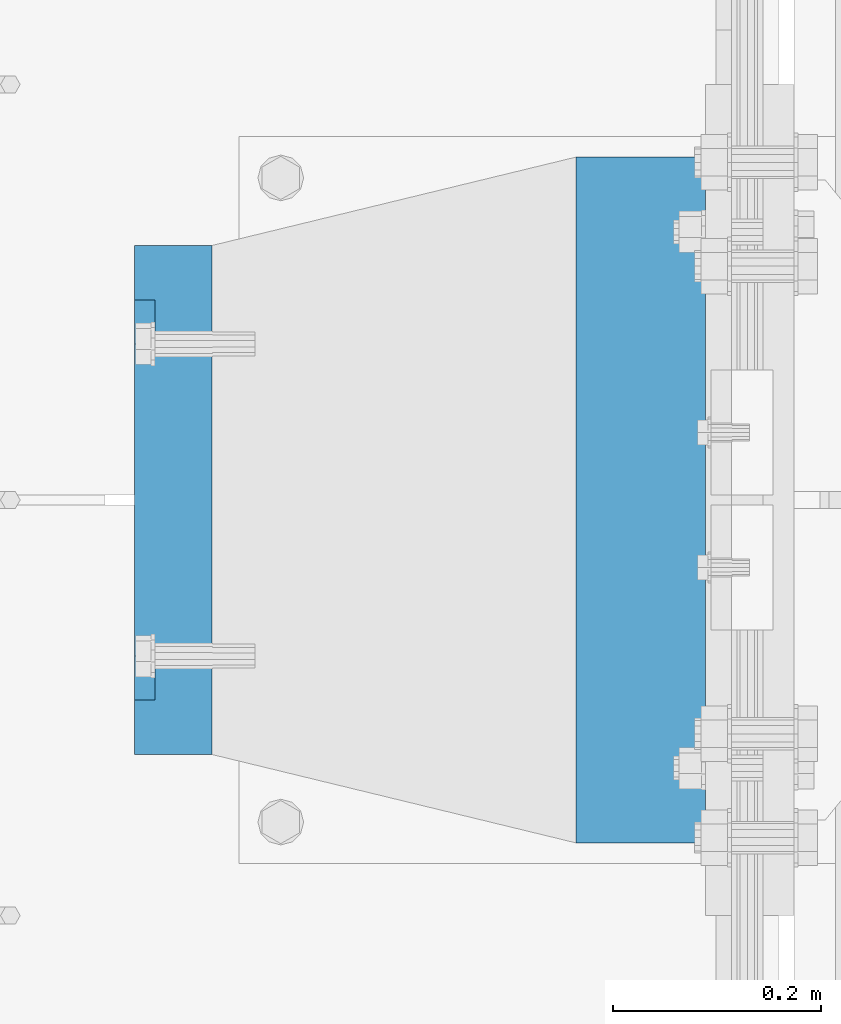
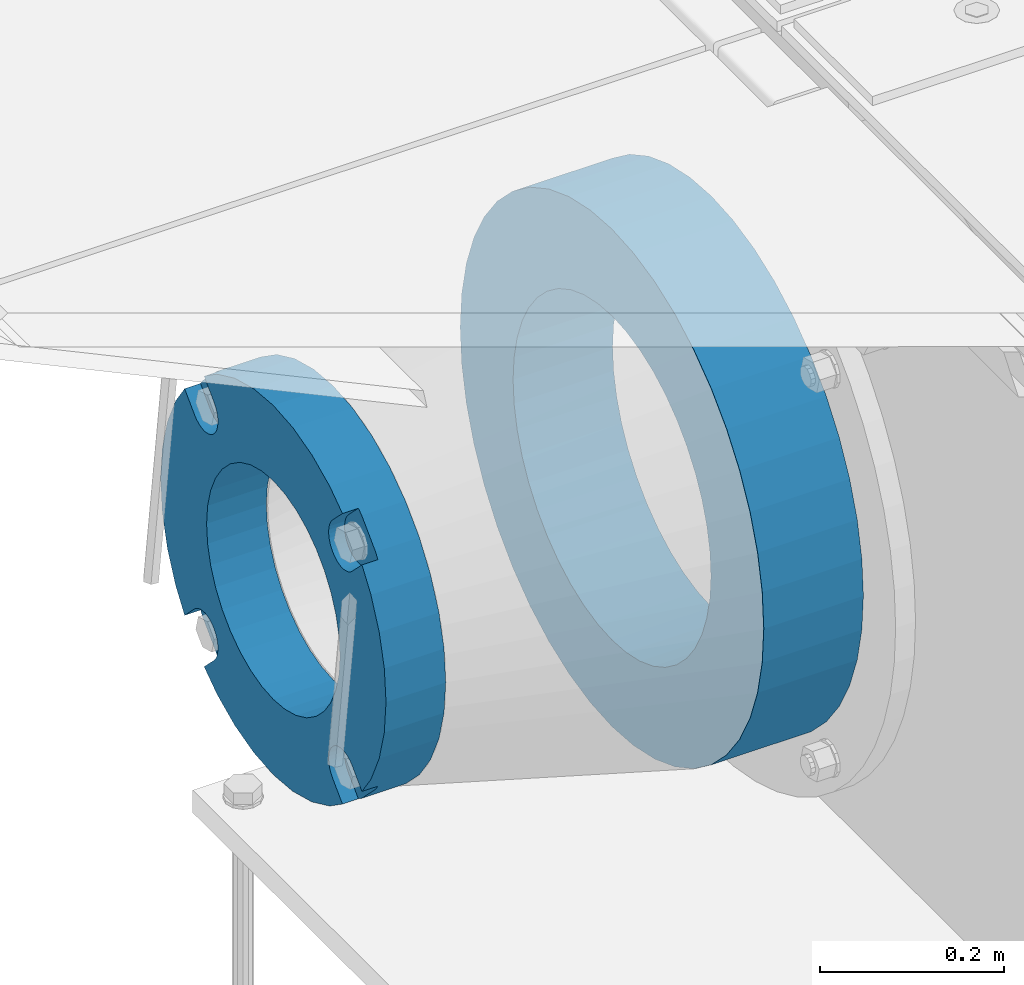
# One storey, part 144 of 257: 2 beams.
"""IFC2X3 building model written with IfcOpenShell, lengths in millimetres."""

from ifc_helpers import new_model, si_unit, frame, origin_with_axes, place, context, subcontext, project, spatial, faceted_brep, material, type_object, element, save


model = new_model("IFC2X3")

# Units and contexts
model_context = context("Model", 3, precision=1e-05, world=origin_with_axes())
body_context = subcontext(model_context, "Body", "Model", "MODEL_VIEW")
ifc_project = project(units=[si_unit("LENGTHUNIT", "METRE", prefix="MILLI"), si_unit("AREAUNIT", "SQUARE_METRE"), si_unit("VOLUMEUNIT", "CUBIC_METRE"), si_unit("MASSUNIT", "GRAM", prefix="KILO"), si_unit("TIMEUNIT", "SECOND"), si_unit("PLANEANGLEUNIT", "RADIAN"), si_unit("SOLIDANGLEUNIT", "STERADIAN"), si_unit("THERMODYNAMICTEMPERATUREUNIT", "DEGREE_CELSIUS"), si_unit("LUMINOUSINTENSITYUNIT", "LUMEN")], contexts=[model_context])

# Site, building, storey
site_placement = place(None, origin_with_axes())
site = spatial("IfcSite", under=ifc_project, at=site_placement, CompositionType="ELEMENT")
building_placement = place(site_placement, origin_with_axes())
building = spatial("IfcBuilding", under=site, at=building_placement, Name="Standard", CompositionType="ELEMENT")
storey_placement = place(building_placement, origin_with_axes())
storey = spatial("IfcBuildingStorey", under=building, at=storey_placement, Name="Undefined", CompositionType="ELEMENT", Elevation=0.0)

# Beams
ifc_material_1 = material(Name="SCN-500-E2")
beam_type_1 = type_object("IfcBeamType", PredefinedType="NOTDEFINED")
beam_1_placement = place(storey_placement, frame((41900.0, 9000.00000146624, -515.0), z_axis=(0.0, 0.0, 1.0), x_axis=(-1.0, 0.0, 0.0)))
element("IfcBeam", 1, at=beam_1_placement, inside=storey, type_object=beam_type_1, material=ifc_material_1, context=body_context, shape_type="Brep", body=[
    faceted_brep([(75.0, 192.717024793295, -150.290616455866), (75.0000000000073, 171.473395903973, -129.046987566545), (55.0, 171.473395903973, -129.046987566545), (55.0, 192.717024793295, -150.290616455866), (75.0000000000073, 167.467485558908, -125.685629673472), (55.0, 167.467485558908, -125.685629673472), (75.0000000000073, 162.938740320598, -123.070957391043), (55.0, 162.938740320598, -123.070957391043), (75.0000000000073, 158.024763821452, -121.28241621347), (55.0, 158.024763821452, -121.28241621347), (75.0000000000073, 152.874864750806, -120.37435005939), (55.0, 152.874864750806, -120.37435005939), (75.0000000000073, 147.645520185947, -120.37435005939), (55.0, 147.645520185947, -120.37435005939), (75.0000000000073, 142.495621115301, -121.28241621347), (55.0, 142.495621115301, -121.28241621347), (75.0000000000073, 137.581644616156, -123.070957391043), (55.0, 137.581644616156, -123.070957391043), (75.0000000000073, 133.052899377846, -125.685629673472), (55.0, 133.052899377846, -125.685629673472), (75.0000000000073, 129.04698903278, -129.046987566545), (55.0, 129.04698903278, -129.046987566545), (75.0000000000073, 125.685631139707, -133.05289791161), (55.0, 125.685631139707, -133.05289791161), (75.0000000000073, 123.070958857277, -137.58164314992), (55.0, 123.070958857277, -137.58164314992), (75.0000000000073, 121.282417679704, -142.495619649066), (55.0, 121.282417679704, -142.495619649066), (75.0, 120.374351525624, -147.645518719712), (55.0, 120.374351525624, -147.645518719712), (75.0, 120.374351525624, -152.874863284572), (55.0, 120.374351525624, -152.874863284572), (75.0000000000073, 121.282417679704, -158.024762355218), (55.0, 121.282417679704, -158.024762355218), (75.0000000000073, 123.070958857277, -162.938738854363), (55.0, 123.070958857277, -162.938738854363), (75.0000000000073, 125.685631139707, -167.467484092674), (55.0, 125.685631139707, -167.467484092674), (75.0000000000073, 129.04698903278, -171.473394437738), (55.0, 129.04698903278, -171.473394437738), (55.0, 150.290618180639, -192.717023585596), (75.0, 150.290618180639, -192.717023585596), (55.0, 157.482964373202, -187.68088856415), (55.0, 187.68088856415, -157.482964373202), (75.0, -192.717023585595, 150.29061818064), (75.0000000000073, -171.4733929715, 129.046987566545), (55.0, -171.4733929715, 129.046987566545), (55.0, -192.717023585596, 150.29061818064), (75.0000000000073, -167.467482626435, 125.685629673472), (55.0, -167.467482626435, 125.685629673472), (75.0000000000073, -162.938737388125, 123.070957391043), (55.0, -162.938737388125, 123.070957391043), (75.0000000000073, -158.024760888979, 121.28241621347), (55.0, -158.024760888979, 121.28241621347), (75.0000000000073, -152.874861818334, 120.37435005939), (55.0, -152.874861818334, 120.37435005939), (75.0000000000073, -147.645517253474, 120.37435005939), (55.0, -147.645517253474, 120.37435005939), (75.0000000000073, -142.495618182828, 121.28241621347), (55.0, -142.495618182828, 121.28241621347), (75.0, -137.581641683683, 123.070957391043), (55.0, -137.581641683683, 123.070957391043), (75.0, -133.052896445373, 125.685629673473), (55.0, -133.052896445373, 125.685629673473), (75.0, -129.046986100308, 129.046987566545), (55.0, -129.046986100308, 129.046987566545), (75.0, -125.685628207234, 133.05289791161), (55.0, -125.685628207234, 133.05289791161), (75.0, -123.070955924804, 137.581643149921), (55.0, -123.070955924804, 137.581643149921), (75.0, -121.282414747231, 142.495619649066), (55.0, -121.282414747231, 142.495619649066), (75.0, -120.374348593151, 147.645518719712), (55.0, -120.374348593151, 147.645518719712), (75.0, -120.374348593151, 152.874863284572), (55.0, -120.374348593151, 152.874863284572), (75.0, -121.282414747231, 158.024762355218), (55.0, -121.282414747231, 158.024762355218), (75.0, -123.070955924804, 162.938738854364), (55.0, -123.070955924804, 162.938738854364), (75.0, -125.685628207234, 167.467484092675), (55.0, -125.685628207234, 167.467484092675), (75.0, -129.046986100308, 171.473394437738), (55.0, -129.046986100308, 171.473394437738), (55.0, -150.290616455865, 192.717024793296), (75.0, -150.290616455865, 192.717024793296), (75.0, 150.290618180638, 192.717023585597), (75.0, 129.04698903278, 171.473394437739), (55.0, 129.04698903278, 171.473394437739), (55.0, 150.290618180638, 192.717023585597), (75.0, 125.685631139708, 167.467484092674), (55.0, 125.685631139708, 167.467484092674), (75.0, 123.070958857278, 162.938738854363), (55.0, 123.070958857278, 162.938738854363), (75.0, 121.282417679706, 158.024762355218), (55.0, 121.282417679706, 158.024762355218), (75.0, 120.374351525625, 152.874863284572), (55.0, 120.374351525625, 152.874863284572), (75.0, 120.374351525625, 147.645518719713), (55.0, 120.374351525625, 147.645518719713), (75.0, 121.282417679706, 142.495619649067), (55.0, 121.282417679706, 142.495619649067), (75.0, 123.070958857278, 137.581643149922), (55.0, 123.070958857278, 137.581643149922), (75.0, 125.685631139708, 133.052897911612), (55.0, 125.685631139708, 133.052897911612), (75.0, 129.04698903278, 129.046987566546), (55.0, 129.04698903278, 129.046987566546), (75.0, 133.052899377845, 125.685629673472), (55.0, 133.052899377845, 125.685629673472), (75.0, 137.581644616156, 123.070957391043), (55.0, 137.581644616156, 123.070957391043), (75.0, 142.495621115301, 121.28241621347), (55.0, 142.495621115301, 121.28241621347), (75.0, 147.645520185948, 120.37435005939), (55.0, 147.645520185948, 120.37435005939), (75.0, 152.874864750807, 120.37435005939), (55.0, 152.874864750807, 120.37435005939), (75.0, 158.024763821453, 121.28241621347), (55.0, 158.024763821453, 121.28241621347), (75.0, 162.938740320599, 123.070957391043), (55.0, 162.938740320599, 123.070957391043), (75.0, 167.46748555891, 125.685629673472), (55.0, 167.46748555891, 125.685629673472), (75.0, 171.473395903973, 129.046987566546), (55.0, 171.473395903973, 129.046987566546), (55.0, 192.717024793294, 150.290616455867), (75.0, 192.717024793294, 150.290616455867), (0.0, 212.176223927188, -122.5), (0.0, 230.224692092548, -83.7949351147888), (75.0, 230.224692092548, -83.7949351147888), (75.0, 212.176223927188, -122.5), (0.0, 241.277899487991, -42.5438035283978), (75.0, 241.277899487991, -42.5438035283978), (0.0, 245.0, 0.0), (75.0, 245.0, 0.0), (0.0, 241.277899487991, 42.543803528398), (75.0, 241.277899487991, 42.543803528398), (0.0, 230.224692092548, 83.7949351147889), (75.0, 230.224692092548, 83.7949351147889), (0.0, 212.176223927187, 122.5), (75.0, 212.176223927187, 122.5), (0.0, 187.68088856415, 157.482964373202), (55.0, 187.68088856415, 157.482964373202), (0.0, 157.482964373202, 187.68088856415), (55.0, 157.482964373202, 187.68088856415), (0.0, 122.5, 212.176223927187), (75.0, 122.5, 212.176223927187), (0.0, 83.7949351147888, 230.224692092548), (75.0, 83.7949351147888, 230.224692092548), (0.0, 42.5438035283979, 241.277899487991), (75.0, 42.5438035283979, 241.277899487991), (0.0, -1.50019233485983e-14, 245.0), (75.0, -1.50019233485983e-14, 245.0), (0.0, -42.543803528398, 241.277899487991), (75.0, -42.543803528398, 241.277899487991), (0.0, -83.7949351147889, 230.224692092548), (75.0, -83.7949351147889, 230.224692092548), (0.0, -122.5, 212.176223927187), (75.0, -122.5, 212.176223927187), (0.0, -157.482964373202, 187.68088856415), (55.0, -157.482964373202, 187.68088856415), (0.0, -187.68088856415, 157.482964373202), (55.0, -187.68088856415, 157.482964373202), (0.0, -212.176223927187, 122.5), (75.0, -212.176223927187, 122.5), (0.0, -230.224692092548, 83.7949351147888), (75.0, -230.224692092548, 83.7949351147888), (0.0, -241.277899487991, 42.5438035283979), (75.0, -241.277899487991, 42.5438035283979), (0.0, -245.0, 0.0), (75.0, -245.0, 0.0), (0.0, -187.68088856415, -157.482964373202), (0.0, -157.482964373202, -187.68088856415), (55.0, -157.482964373202, -187.68088856415), (55.0, -187.68088856415, -157.482964373202), (0.0, 83.794935114789, -230.224692092547), (0.0, 122.5, -212.176223927187), (75.0, 122.5, -212.176223927187), (75.0, 83.794935114789, -230.224692092547), (0.0, 42.5438035283979, -241.277899487991), (75.0, 42.5438035283979, -241.277899487991), (0.0, 4.50057698340366e-14, -245.0), (75.0, 4.50057698340366e-14, -245.0), (0.0, -42.5438035283978, -241.277899487991), (75.0, -42.5438035283978, -241.277899487991), (0.0, -83.7949351147887, -230.224692092548), (75.0, -83.7949351147887, -230.224692092548), (0.0, -122.5, -212.176223927187), (75.0, -122.5, -212.176223927187), (75.0, -150.290616455865, -192.717024793296), (55.0, -150.290616455865, -192.717024793296), (55.0, -129.046986100307, -171.473394437739), (55.0, -125.685628207235, -167.467484092674), (55.0, -123.070955924805, -162.938738854363), (55.0, -121.282414747233, -158.024762355218), (55.0, -120.374348593152, -152.874863284572), (55.0, -120.374348593153, -147.645518719713), (55.0, -121.282414747233, -142.495619649067), (55.0, -123.070955924805, -137.581643149922), (55.0, -125.685628207235, -133.052897911612), (55.0, -129.046986100307, -129.046987566546), (55.0, -133.052896445372, -125.685629673472), (55.0, -137.581641683683, -123.070957391043), (55.0, -142.495618182829, -121.28241621347), (55.0, -147.645517253475, -120.37435005939), (55.0, -152.874861818334, -120.37435005939), (55.0, -158.024760888981, -121.28241621347), (55.0, -162.938737388126, -123.070957391043), (55.0, -167.467482626437, -125.685629673472), (55.0, -171.4733929715, -129.046987566546), (55.0, -192.717023585595, -150.290618180641), (75.0, -129.046986100307, -171.473394437739), (75.0, -125.685628207235, -167.467484092674), (75.0, -123.070955924805, -162.938738854363), (75.0, -121.282414747233, -158.024762355218), (75.0, -120.374348593152, -152.874863284572), (75.0, -120.374348593153, -147.645518719713), (75.0, -121.282414747233, -142.495619649067), (75.0, -123.070955924805, -137.581643149922), (75.0, -125.685628207235, -133.052897911612), (75.0, -129.046986100307, -129.046987566546), (75.0, -133.052896445372, -125.685629673472), (75.0, -137.581641683683, -123.070957391043), (75.0, -142.495618182829, -121.28241621347), (75.0, -147.645517253475, -120.37435005939), (75.0, -152.874861818334, -120.37435005939), (75.0, -158.024760888981, -121.28241621347), (75.0, -162.938737388126, -123.070957391043), (75.0, -167.467482626437, -125.685629673472), (75.0, -171.4733929715, -129.046987566546), (75.0, -192.717023585595, -150.290618180641), (75.0, -212.176223927187, -122.5), (0.0, -212.176223927187, -122.5), (0.0, -230.224692092547, -83.794935114789), (75.0, -230.224692092547, -83.794935114789), (0.0, -241.277899487991, -42.5438035283979), (75.0, -241.277899487991, -42.5438035283979), (0.0, 187.68088856415, -157.482964373202), (0.0, 157.482964373202, -187.68088856415), (0.0, -142.79712418677, -25.1789857617049), (0.0, -136.255430013957, -49.592920782222), (0.0, -125.573683548744, -72.5), (0.0, -111.076444252252, -93.2042034045483), (0.0, -93.2042034045482, -111.076444252252), (0.0, -72.5, -125.573683548744), (0.0, -49.592920782222, -136.255430013957), (0.0, -25.1789857617049, -142.79712418677), (0.0, -8.87868935037022e-15, -145.0), (0.0, 25.1789857617049, -142.79712418677), (0.0, 49.592920782222, -136.255430013957), (0.0, 72.5, -125.573683548744), (0.0, 93.2042034045482, -111.076444252252), (0.0, 111.076444252252, -93.2042034045483), (0.0, 125.573683548744, -72.5), (0.0, 136.255430013957, -49.592920782222), (0.0, 142.79712418677, -25.178985761705), (0.0, 145.0, 0.0), (0.0, 142.79712418677, 25.1789857617048), (0.0, 136.255430013957, 49.5929207822219), (0.0, 125.573683548744, 72.4999999999999), (0.0, 111.076444252252, 93.2042034045482), (0.0, 93.2042034045482, 111.076444252252), (0.0, 72.5000000000001, 125.573683548744), (0.0, 49.5929207822221, 136.255430013957), (0.0, 25.1789857617049, 142.79712418677), (0.0, 2.66360678393524e-14, 145.0), (0.0, -25.1789857617048, 142.79712418677), (0.0, -49.5929207822219, 136.255430013957), (0.0, -72.5, 125.573683548744), (0.0, -93.2042034045482, 111.076444252252), (0.0, -111.076444252252, 93.2042034045483), (0.0, -125.573683548744, 72.5000000000001), (0.0, -136.255430013957, 49.5929207822221), (0.0, -142.79712418677, 25.1789857617049), (0.0, -145.0, 0.0), (75.0, -145.0, 0.0), (75.0, -142.79712418677, -25.1789857617049), (75.0, -136.255430013957, -49.592920782222), (75.0, -125.573683548744, -72.5), (75.0, -111.076444252252, -93.2042034045483), (75.0, -93.2042034045482, -111.076444252252), (75.0, -72.5, -125.573683548744), (75.0, -49.592920782222, -136.255430013957), (75.0, -25.1789857617049, -142.79712418677), (75.0, -8.87868935037022e-15, -145.0), (75.0, 25.1789857617049, -142.79712418677), (75.0, 49.592920782222, -136.255430013957), (75.0, 72.5, -125.573683548744), (75.0, 93.2042034045482, -111.076444252252), (75.0, 111.076444252252, -93.2042034045483), (75.0, 125.573683548744, -72.5), (75.0, 136.255430013957, -49.592920782222), (75.0, 142.79712418677, -25.178985761705), (75.0, 145.0, 0.0), (75.0, 142.79712418677, 25.1789857617048), (75.0, 136.255430013957, 49.5929207822219), (75.0, 125.573683548744, 72.4999999999999), (75.0, 111.076444252252, 93.2042034045482), (75.0, 93.2042034045482, 111.076444252252), (75.0, 72.5000000000001, 125.573683548744), (75.0, 49.5929207822221, 136.255430013957), (75.0, 25.1789857617049, 142.79712418677), (75.0, 2.66360678393524e-14, 145.0), (75.0, -25.1789857617048, 142.79712418677), (75.0, -49.5929207822219, 136.255430013957), (75.0, -72.5, 125.573683548744), (75.0, -93.2042034045482, 111.076444252252), (75.0, -111.076444252252, 93.2042034045483), (75.0, -125.573683548744, 72.5000000000001), (75.0, -136.255430013957, 49.5929207822221), (75.0, -142.79712418677, 25.1789857617049)], [[[0, 1, 2, 3]], [[4, 5, 2, 1]], [[6, 7, 5, 4]], [[8, 9, 7, 6]], [[10, 11, 9, 8]], [[12, 13, 11, 10]], [[14, 15, 13, 12]], [[16, 17, 15, 14]], [[18, 19, 17, 16]], [[20, 21, 19, 18]], [[22, 23, 21, 20]], [[24, 25, 23, 22]], [[26, 27, 25, 24]], [[28, 29, 27, 26]], [[30, 31, 29, 28]], [[32, 33, 31, 30]], [[34, 35, 33, 32]], [[36, 37, 35, 34]], [[38, 39, 37, 36]], [[40, 39, 38, 41]], [[42, 43, 3, 2, 5, 7, 9, 11, 13, 15, 17, 19, 21, 23, 25, 27, 29, 31, 33, 35, 37, 39, 40]], [[44, 45, 46, 47]], [[48, 49, 46, 45]], [[50, 51, 49, 48]], [[52, 53, 51, 50]], [[54, 55, 53, 52]], [[56, 57, 55, 54]], [[58, 59, 57, 56]], [[60, 61, 59, 58]], [[62, 63, 61, 60]], [[64, 65, 63, 62]], [[66, 67, 65, 64]], [[68, 69, 67, 66]], [[70, 71, 69, 68]], [[72, 73, 71, 70]], [[74, 75, 73, 72]], [[76, 77, 75, 74]], [[78, 79, 77, 76]], [[80, 81, 79, 78]], [[82, 83, 81, 80]], [[84, 83, 82, 85]], [[86, 87, 88, 89]], [[90, 91, 88, 87]], [[92, 93, 91, 90]], [[94, 95, 93, 92]], [[96, 97, 95, 94]], [[98, 99, 97, 96]], [[100, 101, 99, 98]], [[102, 103, 101, 100]], [[104, 105, 103, 102]], [[106, 107, 105, 104]], [[108, 109, 107, 106]], [[110, 111, 109, 108]], [[112, 113, 111, 110]], [[114, 115, 113, 112]], [[116, 117, 115, 114]], [[118, 119, 117, 116]], [[120, 121, 119, 118]], [[122, 123, 121, 120]], [[124, 125, 123, 122]], [[126, 125, 124, 127]], [[128, 129, 130, 131]], [[129, 132, 133, 130]], [[132, 134, 135, 133]], [[134, 136, 137, 135]], [[136, 138, 139, 137]], [[138, 140, 141, 139]], [[127, 141, 140, 142, 143, 126]], [[142, 144, 145, 143]], [[89, 88, 91, 93, 95, 97, 99, 101, 103, 105, 107, 109, 111, 113, 115, 117, 119, 121, 123, 125, 126, 143, 145]], [[144, 146, 147, 86, 89, 145]], [[146, 148, 149, 147]], [[148, 150, 151, 149]], [[150, 152, 153, 151]], [[152, 154, 155, 153]], [[154, 156, 157, 155]], [[156, 158, 159, 157]], [[85, 159, 158, 160, 161, 84]], [[160, 162, 163, 161]], [[47, 46, 49, 51, 53, 55, 57, 59, 61, 63, 65, 67, 69, 71, 73, 75, 77, 79, 81, 83, 84, 161, 163]], [[162, 164, 165, 44, 47, 163]], [[164, 166, 167, 165]], [[166, 168, 169, 167]], [[168, 170, 171, 169]], [[172, 173, 174, 175]], [[176, 177, 178, 179]], [[180, 176, 179, 181]], [[182, 180, 181, 183]], [[184, 182, 183, 185]], [[186, 184, 185, 187]], [[188, 186, 187, 189]], [[173, 188, 189, 190, 191, 174]], [[175, 174, 191, 192, 193, 194, 195, 196, 197, 198, 199, 200, 201, 202, 203, 204, 205, 206, 207, 208, 209, 210, 211]], [[190, 212, 192, 191]], [[213, 193, 192, 212]], [[214, 194, 193, 213]], [[215, 195, 194, 214]], [[216, 196, 195, 215]], [[217, 197, 196, 216]], [[218, 198, 197, 217]], [[219, 199, 198, 218]], [[220, 200, 199, 219]], [[221, 201, 200, 220]], [[222, 202, 201, 221]], [[223, 203, 202, 222]], [[224, 204, 203, 223]], [[225, 205, 204, 224]], [[226, 206, 205, 225]], [[227, 207, 206, 226]], [[228, 208, 207, 227]], [[229, 209, 208, 228]], [[230, 210, 209, 229]], [[211, 210, 230, 231]], [[232, 233, 172, 175, 211, 231]], [[234, 233, 232, 235]], [[236, 234, 235, 237]], [[170, 236, 237, 171]], [[168, 166, 164, 162, 160, 158, 156, 154, 152, 150, 148, 146, 144, 142, 140, 138, 136, 134, 132, 129, 128, 238, 239, 177, 176, 180, 182, 184, 186, 188, 173, 172, 233, 234, 236, 170], [240, 241, 242, 243, 244, 245, 246, 247, 248, 249, 250, 251, 252, 253, 254, 255, 256, 257, 258, 259, 260, 261, 262, 263, 264, 265, 266, 267, 268, 269, 270, 271, 272, 273, 274, 275]], [[240, 275, 276, 277]], [[241, 240, 277, 278]], [[242, 241, 278, 279]], [[243, 242, 279, 280]], [[244, 243, 280, 281]], [[245, 244, 281, 282]], [[246, 245, 282, 283]], [[247, 246, 283, 284]], [[248, 247, 284, 285]], [[249, 248, 285, 286]], [[250, 249, 286, 287]], [[251, 250, 287, 288]], [[252, 251, 288, 289]], [[253, 252, 289, 290]], [[254, 253, 290, 291]], [[255, 254, 291, 292]], [[256, 255, 292, 293]], [[257, 256, 293, 294]], [[258, 257, 294, 295]], [[259, 258, 295, 296]], [[260, 259, 296, 297]], [[261, 260, 297, 298]], [[262, 261, 298, 299]], [[263, 262, 299, 300]], [[264, 263, 300, 301]], [[265, 264, 301, 302]], [[266, 265, 302, 303]], [[267, 266, 303, 304]], [[268, 267, 304, 305]], [[269, 268, 305, 306]], [[270, 269, 306, 307]], [[271, 270, 307, 308]], [[272, 271, 308, 309]], [[273, 272, 309, 310]], [[274, 273, 310, 311]], [[275, 274, 311, 276]], [[24, 22, 20, 18, 16, 14, 12, 10, 8, 6, 4, 1, 0, 131, 130, 133, 135, 137, 139, 141, 127, 124, 122, 120, 118, 116, 114, 112, 110, 108, 106, 104, 102, 100, 98, 96, 94, 92, 90, 87, 86, 147, 149, 151, 153, 155, 157, 159, 85, 82, 80, 78, 76, 74, 72, 70, 68, 66, 64, 62, 60, 58, 56, 54, 52, 50, 48, 45, 44, 165, 167, 169, 171, 237, 235, 232, 231, 230, 229, 228, 227, 226, 225, 224, 223, 222, 221, 220, 219, 218, 217, 216, 215, 214, 213, 212, 190, 189, 187, 185, 183, 181, 179, 178, 41, 38, 36, 34, 32, 30, 28, 26], [310, 309, 308, 307, 306, 305, 304, 303, 302, 301, 300, 299, 298, 297, 296, 295, 294, 293, 292, 291, 290, 289, 288, 287, 286, 285, 284, 283, 282, 281, 280, 279, 278, 277, 276, 311]], [[238, 128, 131, 0, 3, 43]], [[239, 238, 43, 42]], [[178, 177, 239, 42, 40, 41]]]),
])
ifc_material_2 = material(Name="STEEL/S355N")
beam_type_2 = type_object("IfcBeamType", PredefinedType="NOTDEFINED")
beam_2_placement = place(storey_placement, frame((42375.0, 9000.0, -515.0), z_axis=(0.0, 0.0, 1.0), x_axis=(-1.0, 0.0, 0.0)))
element("IfcBeam", 2, at=beam_2_placement, inside=storey, type_object=beam_type_2, material=ifc_material_2, context=body_context, shape_type="Brep", body=[
    faceted_brep([(0.0, -215.0, 0.0), (0.0, -212.811610004401, 30.5976902287563), (125.0, -212.811610004401, 30.5976902287563), (125.0, -215.0, 0.0), (0.0, -206.290989327117, 60.5724997209074), (125.0, -206.290989327117, 60.5724997209074), (0.0, -195.570879001221, 89.3142277954056), (125.0, -195.570879001221, 89.3142277954056), (0.0, -180.869509558704, 116.237775752953), (125.0, -180.869509558704, 116.237775752953), (0.0, -162.486158486166, 140.795057798236), (125.0, -162.486158486166, 140.795057798236), (0.0, -140.795057798236, 162.486158486165), (125.0, -140.795057798236, 162.486158486165), (0.0, -116.237775752953, 180.869509558704), (125.0, -116.237775752953, 180.869509558704), (0.0, -89.3142277954055, 195.570879001222), (125.0, -89.3142277954055, 195.570879001222), (0.0, -60.5724997209073, 206.290989327117), (125.0, -60.5724997209073, 206.290989327117), (0.0, -30.5976902287562, 212.811610004401), (125.0, -30.5976902287562, 212.811610004401), (0.0, 3.94948592725021e-14, 215.0), (125.0, 3.94948592725021e-14, 215.0), (0.0, 30.5976902287563, 212.811610004401), (125.0, 30.5976902287563, 212.811610004401), (0.0, 60.5724997209074, 206.290989327117), (125.0, 60.5724997209074, 206.290989327117), (0.0, 89.3142277954056, 195.570879001221), (125.0, 89.3142277954056, 195.570879001221), (0.0, 116.237775752953, 180.869509558704), (125.0, 116.237775752953, 180.869509558704), (0.0, 140.795057798236, 162.486158486165), (125.0, 140.795057798236, 162.486158486165), (0.0, 162.486158486166, 140.795057798236), (125.0, 162.486158486166, 140.795057798236), (0.0, 180.869509558704, 116.237775752953), (125.0, 180.869509558704, 116.237775752953), (0.0, 195.570879001221, 89.3142277954056), (125.0, 195.570879001221, 89.3142277954056), (0.0, 206.290989327117, 60.5724997209073), (125.0, 206.290989327117, 60.5724997209073), (0.0, 212.811610004401, 30.5976902287563), (125.0, 212.811610004401, 30.5976902287563), (0.0, 215.0, 0.0), (125.0, 215.0, 0.0), (0.0, 212.811610004401, -30.5976902287563), (125.0, 212.811610004401, -30.5976902287563), (0.0, 206.290989327117, -60.5724997209073), (125.0, 206.290989327117, -60.5724997209073), (0.0, 195.570879001221, -89.3142277954056), (125.0, 195.570879001221, -89.3142277954056), (0.0, 180.869509558704, -116.237775752954), (125.0, 180.869509558704, -116.237775752954), (0.0, 162.486158486165, -140.795057798236), (125.0, 162.486158486165, -140.795057798236), (0.0, 140.795057798236, -162.486158486166), (125.0, 140.795057798236, -162.486158486166), (0.0, 116.237775752953, -180.869509558704), (125.0, 116.237775752953, -180.869509558704), (0.0, 89.3142277954056, -195.570879001221), (125.0, 89.3142277954056, -195.570879001221), (0.0, 60.5724997209074, -206.290989327117), (125.0, 60.5724997209074, -206.290989327117), (0.0, 30.5976902287563, -212.811610004401), (125.0, 30.5976902287563, -212.811610004401), (0.0, -1.3164953090834e-14, -215.0), (125.0, -1.3164953090834e-14, -215.0), (0.0, -30.5976902287563, -212.811610004401), (125.0, -30.5976902287563, -212.811610004401), (0.0, -60.5724997209074, -206.290989327117), (125.0, -60.5724997209074, -206.290989327117), (0.0, -89.3142277954056, -195.570879001221), (125.0, -89.3142277954056, -195.570879001221), (0.0, -116.237775752954, -180.869509558704), (125.0, -116.237775752954, -180.869509558704), (0.0, -140.795057798236, -162.486158486166), (125.0, -140.795057798236, -162.486158486166), (0.0, -162.486158486166, -140.795057798236), (125.0, -162.486158486166, -140.795057798236), (0.0, -180.869509558704, -116.237775752953), (125.0, -180.869509558704, -116.237775752953), (0.0, -195.570879001221, -89.3142277954056), (125.0, -195.570879001221, -89.3142277954056), (0.0, -206.290989327117, -60.5724997209073), (125.0, -206.290989327117, -60.5724997209073), (0.0, -212.811610004401, -30.5976902287563), (125.0, -212.811610004401, -30.5976902287563), (0.0, -330.0, 0.0), (0.0, -326.641075820708, -46.9638966301842), (125.0, -326.641075820708, -46.9638966301842), (125.0, -330.0, 0.0), (0.0, -316.632681292784, -92.9717437576718), (125.0, -316.632681292784, -92.9717437576718), (0.0, -300.178558466991, -137.086954290623), (125.0, -300.178558466991, -137.086954290623), (0.0, -277.61366583429, -178.411469760347), (125.0, -277.61366583429, -178.411469760347), (0.0, -249.397359536905, -216.104042201944), (125.0, -249.397359536905, -216.104042201944), (0.0, -216.104042201944, -249.397359536905), (125.0, -216.104042201944, -249.397359536905), (0.0, -178.411469760347, -277.61366583429), (125.0, -178.411469760347, -277.61366583429), (0.0, -137.086954290622, -300.178558466991), (125.0, -137.086954290622, -300.178558466991), (0.0, -92.9717437576717, -316.632681292784), (125.0, -92.9717437576717, -316.632681292784), (0.0, -46.963896630184, -326.641075820708), (125.0, -46.963896630184, -326.641075820708), (0.0, 6.0620016557794e-14, -330.0), (125.0, 6.0620016557794e-14, -330.0), (0.0, 46.9638966301841, -326.641075820708), (125.0, 46.9638966301841, -326.641075820708), (0.0, 92.9717437576718, -316.632681292784), (125.0, 92.9717437576718, -316.632681292784), (0.0, 137.086954290623, -300.178558466991), (125.0, 137.086954290623, -300.178558466991), (0.0, 178.411469760347, -277.61366583429), (125.0, 178.411469760347, -277.61366583429), (0.0, 216.104042201944, -249.397359536905), (125.0, 216.104042201944, -249.397359536905), (0.0, 249.397359536905, -216.104042201944), (125.0, 249.397359536905, -216.104042201944), (0.0, 277.61366583429, -178.411469760347), (125.0, 277.61366583429, -178.411469760347), (0.0, 300.178558466991, -137.086954290623), (125.0, 300.178558466991, -137.086954290623), (0.0, 316.632681292784, -92.9717437576717), (125.0, 316.632681292784, -92.9717437576717), (0.0, 326.641075820708, -46.9638966301841), (125.0, 326.641075820708, -46.9638966301841), (0.0, 330.0, 0.0), (125.0, 330.0, 0.0), (0.0, 326.641075820708, 46.9638966301841), (125.0, 326.641075820708, 46.9638966301841), (0.0, 316.632681292784, 92.9717437576718), (125.0, 316.632681292784, 92.9717437576718), (0.0, 300.178558466991, 137.086954290622), (125.0, 300.178558466991, 137.086954290622), (0.0, 277.61366583429, 178.411469760347), (125.0, 277.61366583429, 178.411469760347), (0.0, 249.397359536905, 216.104042201944), (125.0, 249.397359536905, 216.104042201944), (0.0, 216.104042201944, 249.397359536905), (125.0, 216.104042201944, 249.397359536905), (0.0, 178.411469760347, 277.61366583429), (125.0, 178.411469760347, 277.61366583429), (0.0, 137.086954290622, 300.178558466991), (125.0, 137.086954290622, 300.178558466991), (0.0, 92.9717437576718, 316.632681292784), (125.0, 92.9717437576718, 316.632681292784), (0.0, 46.9638966301841, 326.641075820708), (125.0, 46.9638966301841, 326.641075820708), (0.0, -2.02066721859313e-14, 330.0), (125.0, -2.02066721859313e-14, 330.0), (0.0, -46.9638966301841, 326.641075820708), (125.0, -46.9638966301841, 326.641075820708), (0.0, -92.9717437576718, 316.632681292784), (125.0, -92.9717437576718, 316.632681292784), (0.0, -137.086954290623, 300.178558466991), (125.0, -137.086954290623, 300.178558466991), (0.0, -178.411469760347, 277.61366583429), (125.0, -178.411469760347, 277.61366583429), (0.0, -216.104042201944, 249.397359536905), (125.0, -216.104042201944, 249.397359536905), (0.0, -249.397359536905, 216.104042201944), (125.0, -249.397359536905, 216.104042201944), (0.0, -277.61366583429, 178.411469760347), (125.0, -277.61366583429, 178.411469760347), (0.0, -300.178558466991, 137.086954290623), (125.0, -300.178558466991, 137.086954290623), (0.0, -316.632681292784, 92.9717437576718), (125.0, -316.632681292784, 92.9717437576718), (0.0, -326.641075820708, 46.9638966301841), (125.0, -326.641075820708, 46.9638966301841)], [[[0, 1, 2, 3]], [[1, 4, 5, 2]], [[4, 6, 7, 5]], [[6, 8, 9, 7]], [[8, 10, 11, 9]], [[10, 12, 13, 11]], [[12, 14, 15, 13]], [[14, 16, 17, 15]], [[16, 18, 19, 17]], [[18, 20, 21, 19]], [[20, 22, 23, 21]], [[22, 24, 25, 23]], [[24, 26, 27, 25]], [[26, 28, 29, 27]], [[28, 30, 31, 29]], [[30, 32, 33, 31]], [[32, 34, 35, 33]], [[34, 36, 37, 35]], [[36, 38, 39, 37]], [[38, 40, 41, 39]], [[40, 42, 43, 41]], [[42, 44, 45, 43]], [[44, 46, 47, 45]], [[46, 48, 49, 47]], [[48, 50, 51, 49]], [[50, 52, 53, 51]], [[52, 54, 55, 53]], [[54, 56, 57, 55]], [[56, 58, 59, 57]], [[58, 60, 61, 59]], [[60, 62, 63, 61]], [[62, 64, 65, 63]], [[64, 66, 67, 65]], [[66, 68, 69, 67]], [[68, 70, 71, 69]], [[70, 72, 73, 71]], [[72, 74, 75, 73]], [[74, 76, 77, 75]], [[76, 78, 79, 77]], [[78, 80, 81, 79]], [[80, 82, 83, 81]], [[82, 84, 85, 83]], [[84, 86, 87, 85]], [[86, 0, 3, 87]], [[88, 89, 90, 91]], [[89, 92, 93, 90]], [[92, 94, 95, 93]], [[94, 96, 97, 95]], [[96, 98, 99, 97]], [[98, 100, 101, 99]], [[100, 102, 103, 101]], [[102, 104, 105, 103]], [[104, 106, 107, 105]], [[106, 108, 109, 107]], [[108, 110, 111, 109]], [[110, 112, 113, 111]], [[112, 114, 115, 113]], [[114, 116, 117, 115]], [[116, 118, 119, 117]], [[118, 120, 121, 119]], [[120, 122, 123, 121]], [[122, 124, 125, 123]], [[124, 126, 127, 125]], [[126, 128, 129, 127]], [[128, 130, 131, 129]], [[130, 132, 133, 131]], [[132, 134, 135, 133]], [[134, 136, 137, 135]], [[136, 138, 139, 137]], [[138, 140, 141, 139]], [[140, 142, 143, 141]], [[142, 144, 145, 143]], [[144, 146, 147, 145]], [[146, 148, 149, 147]], [[148, 150, 151, 149]], [[150, 152, 153, 151]], [[152, 154, 155, 153]], [[154, 156, 157, 155]], [[156, 158, 159, 157]], [[158, 160, 161, 159]], [[160, 162, 163, 161]], [[162, 164, 165, 163]], [[164, 166, 167, 165]], [[166, 168, 169, 167]], [[168, 170, 171, 169]], [[170, 172, 173, 171]], [[172, 174, 175, 173]], [[174, 88, 91, 175]], [[93, 95, 97, 99, 101, 103, 105, 107, 109, 111, 113, 115, 117, 119, 121, 123, 125, 127, 129, 131, 133, 135, 137, 139, 141, 143, 145, 147, 149, 151, 153, 155, 157, 159, 161, 163, 165, 167, 169, 171, 173, 175, 91, 90], [5, 7, 9, 11, 13, 15, 17, 19, 21, 23, 25, 27, 29, 31, 33, 35, 37, 39, 41, 43, 45, 47, 49, 51, 53, 55, 57, 59, 61, 63, 65, 67, 69, 71, 73, 75, 77, 79, 81, 83, 85, 87, 3, 2]], [[174, 172, 170, 168, 166, 164, 162, 160, 158, 156, 154, 152, 150, 148, 146, 144, 142, 140, 138, 136, 134, 132, 130, 128, 126, 124, 122, 120, 118, 116, 114, 112, 110, 108, 106, 104, 102, 100, 98, 96, 94, 92, 89, 88], [86, 84, 82, 80, 78, 76, 74, 72, 70, 68, 66, 64, 62, 60, 58, 56, 54, 52, 50, 48, 46, 44, 42, 40, 38, 36, 34, 32, 30, 28, 26, 24, 22, 20, 18, 16, 14, 12, 10, 8, 6, 4, 1, 0]]]),
])

save(model, "model.ifc")
